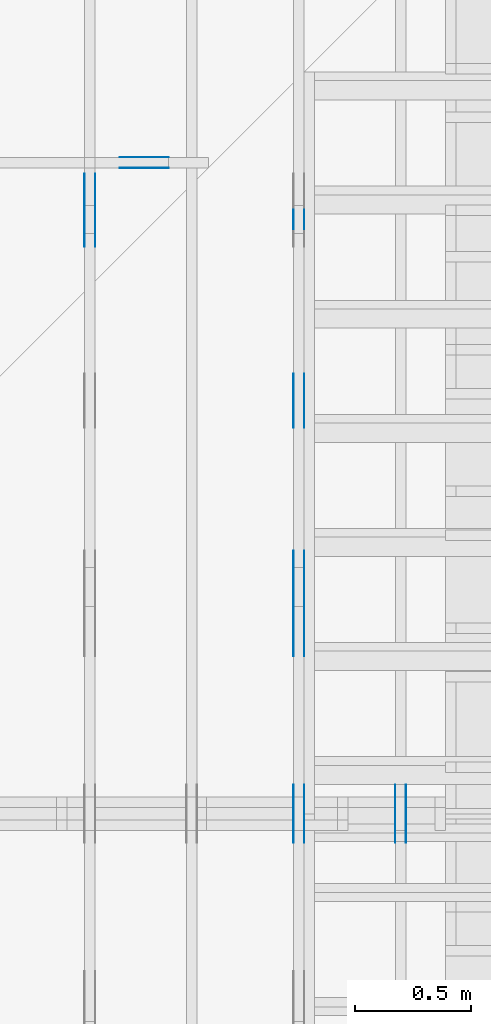
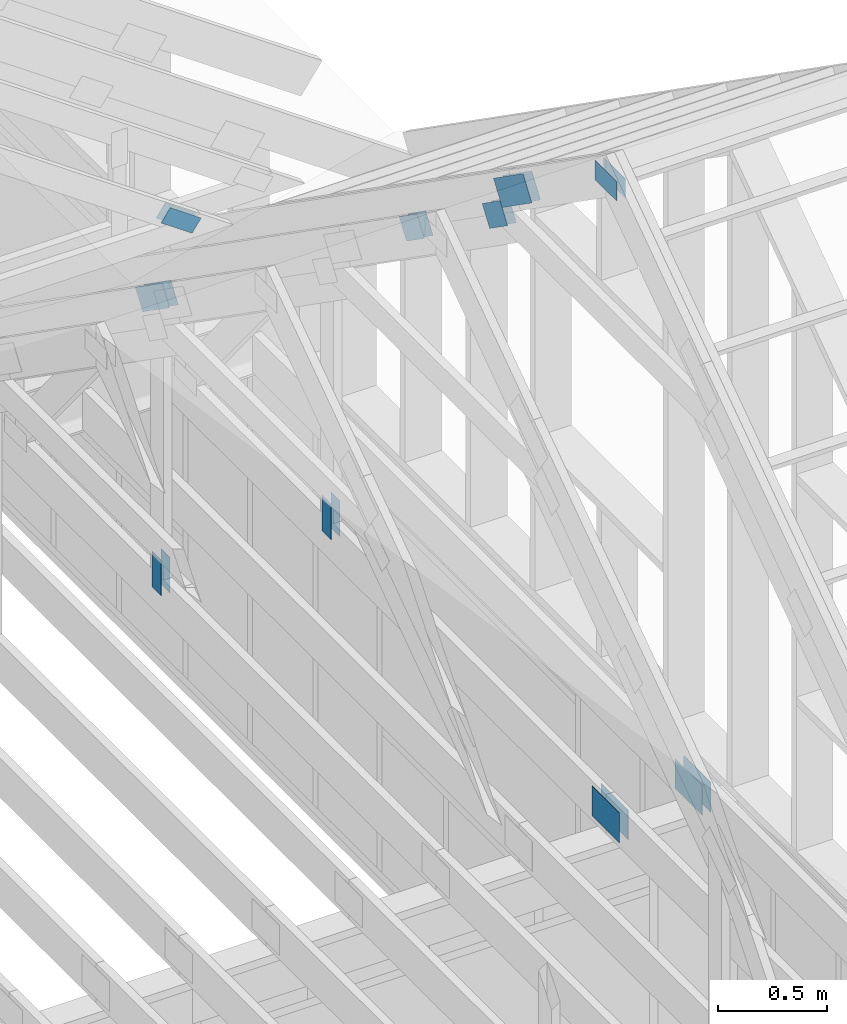
# One storey, part 58 of 70: 20 plates, 4 elements without a shape of their own.
"""IFC2X3 building model written with IfcOpenShell, lengths in millimetres."""

import ifcopenshell
import ifcopenshell.guid

model = None  # the IFC model being written
_history = None  # IfcOwnerHistory: only IFC2X3 demands one
_inside = {}  # id of a spatial element -> (the spatial element, [elements in it])
_under = {}  # id of a project, library or spatial element -> (it, [spatial elements below it])
_declared = {}  # id of a project -> (the project, [libraries it declares])
_typed = {}  # id of a type object -> (the type object, [elements of that type])
_made_of = {}  # id of a material, layer set ... -> (it, [elements and type objects made of it])


def new_model(schema):
    """Start an empty IFC model of exactly this schema.

    Asked for "IFC4X3", IfcOpenShell would pick the latest addendum, in which some entities
    have other attributes; the version numbers below select the first issue.
    IFC2X3 requires an IfcOwnerHistory on every rooted entity: one is made here for all.
    """
    global model, _history
    if schema == "IFC4X3":
        model = ifcopenshell.file(schema_version=(4, 3, 0, 0))
    else:
        model = ifcopenshell.file(schema=schema)
    _inside.clear()
    _under.clear()
    _declared.clear()
    _typed.clear()
    _made_of.clear()
    _history = None
    if model.schema == "IFC2X3":
        org = make("IfcOrganization", Name="unknown")
        user = make(
            "IfcPersonAndOrganization",
            ThePerson=make("IfcPerson", FamilyName="unknown"),
            TheOrganization=org,
        )
        app = make(
            "IfcApplication",
            ApplicationDeveloper=org,
            Version="unknown",
            ApplicationFullName="unknown",
            ApplicationIdentifier="unknown",
        )
        _history = make(
            "IfcOwnerHistory",
            OwningUser=user,
            OwningApplication=app,
            ChangeAction="ADDED",
            CreationDate=0,
        )
    return model


def make(cls, **values):
    """One entity of the class cls with the attributes given. An attribute that is None is left unset."""
    return model.create_entity(
        cls, **{name: value for name, value in values.items() if value is not None}
    )


def rooted(cls, **values):
    """An entity with a GlobalId (a new one), such as an element, a storey or a relation."""
    return make(cls, GlobalId=ifcopenshell.guid.new(), OwnerHistory=_history, **values)


def si_unit(unit_type, name, prefix=None):
    """IfcSIUnit, for example si_unit("LENGTHUNIT", "METRE", prefix="MILLI")."""
    return make("IfcSIUnit", UnitType=unit_type, Prefix=prefix, Name=name)


def assignment(units):
    """IfcUnitAssignment: the units of a project."""
    return None if units is None else make("IfcUnitAssignment", Units=units)


def point(xyz):
    """IfcCartesianPoint."""
    return None if xyz is None else make("IfcCartesianPoint", Coordinates=xyz)


def direction(xyz):
    """IfcDirection."""
    return None if xyz is None else make("IfcDirection", DirectionRatios=xyz)


def frame(location, z_axis=None, x_axis=None):
    """IfcAxis2Placement3D, a coordinate frame: its origin and axes. An axis left out is left unset."""
    return make(
        "IfcAxis2Placement3D",
        Location=point(location),
        Axis=direction(z_axis),
        RefDirection=direction(x_axis),
    )


def frame_2d(location, x_axis=None):
    """IfcAxis2Placement2D, a coordinate frame in the plane: its origin and x axis."""
    return make(
        "IfcAxis2Placement2D", Location=point(location), RefDirection=direction(x_axis)
    )


def origin():
    """The frame at (0, 0, 0) with its axes left unset."""
    return frame((0.0, 0.0, 0.0))


def origin_with_axes():
    """The frame at (0, 0, 0) with the z axis (0, 0, 1) and the x axis (1, 0, 0) written out."""
    return frame((0.0, 0.0, 0.0), z_axis=(0.0, 0.0, 1.0), x_axis=(1.0, 0.0, 0.0))


def origin_2d():
    """The frame at (0, 0) in the plane with its x axis left unset."""
    return frame_2d((0.0, 0.0))


def place(relative_to, where):
    """IfcLocalPlacement: puts the frame where relative to a parent placement (None: the world)."""
    return make(
        "IfcLocalPlacement", PlacementRelTo=relative_to, RelativePlacement=where
    )


def context(
    kind, dimensions, precision=None, world=None, true_north=None, identifier=None
):
    """IfcGeometricRepresentationContext, for example the 3D "Model" context."""
    return make(
        "IfcGeometricRepresentationContext",
        ContextIdentifier=identifier,
        ContextType=kind,
        CoordinateSpaceDimension=dimensions,
        Precision=precision,
        WorldCoordinateSystem=world,
        TrueNorth=true_north,
    )


def project(units=None, contexts=None):
    """IfcProject with its units and contexts."""
    return rooted(
        "IfcProject",
        Name="project",
        RepresentationContexts=contexts,
        UnitsInContext=assignment(units),
    )


def spatial(cls, under=None, at=None, **own):
    """A site, building, storey or space (cls), placed at a placement, below another one or the project."""
    s = rooted(cls, ObjectPlacement=at, **own)
    if under is not None:
        _under.setdefault(under.id(), (under, []))[1].append(s)
    return s


def faces_of(points, faces, orient=None, outer=None):
    """IfcFace entities. A face is a list of loops; a loop is a list of indices into points, from 0.

    orient and outer hold one flag for each loop. By default every Orientation is true, the
    first loop of a face is its IfcFaceOuterBound and the others are IfcFaceBound.
    """
    made = []
    for i, loops in enumerate(faces):
        bounds = []
        for j, loop in enumerate(loops):
            is_outer = j == 0 if outer is None else outer[i][j]
            bounds.append(
                make(
                    "IfcFaceOuterBound" if is_outer else "IfcFaceBound",
                    Bound=make("IfcPolyLoop", Polygon=[points[k] for k in loop]),
                    Orientation=True if orient is None else orient[i][j],
                )
            )
        made.append(make("IfcFace", Bounds=bounds))
    return made


def faceted_brep(points, faces, orient=None, outer=None, voids=None):
    """IfcFacetedBrep: a solid bounded by flat faces; with voids (closed shells), ...WithVoids."""
    shared = [point(p) for p in points]
    hull = make("IfcClosedShell", CfsFaces=faces_of(shared, faces, orient, outer))
    if voids is None:
        return make("IfcFacetedBrep", Outer=hull)
    return make(
        "IfcFacetedBrepWithVoids",
        Outer=hull,
        Voids=[
            make(cls, CfsFaces=faces_of(shared, fs, o, b)) for cls, fs, o, b in voids
        ],
    )


def shape(context_of_items, identifier, shape_type, items):
    """IfcShapeRepresentation: the items that make up one representation, for example the "Body"."""
    return make(
        "IfcShapeRepresentation",
        ContextOfItems=context_of_items,
        RepresentationIdentifier=identifier,
        RepresentationType=shape_type,
        Items=items,
    )


def made_of(thing, what):
    """Note that an element or type object is made of a material, layer set ...; save() writes the relation."""
    if what is not None:
        _made_of.setdefault(what.id(), (what, []))[1].append(thing)
    return thing


def element(
    cls,
    number,
    at=None,
    inside=None,
    cuts=None,
    type_object=None,
    material=None,
    context=None,
    identifier="Body",
    shape_type=None,
    held_by="IfcProductDefinitionShape",
    body=None,
    shapes=None,
    **own,
):
    """One element of the class cls, such as IfcWall. Its Tag is "e" and its number.

    at: its placement. inside: the storey or other place that contains it. cuts: it is an
    opening in that element (IfcRelVoidsElement). A single representation is given by context,
    identifier, shape_type and body (its items); several are given by shapes. held_by: the class
    of the entity that holds the representations. save() writes the other relations.
    """
    e = rooted(cls, Tag="e%d" % number, ObjectPlacement=at, **own)
    if body is not None:
        shapes = [shape(context, identifier, shape_type, body)]
    if shapes is not None:
        e.Representation = make(held_by, Representations=shapes)
    if inside is not None:
        _inside.setdefault(inside.id(), (inside, []))[1].append(e)
    if cuts is not None:
        rooted(
            "IfcRelVoidsElement", RelatingBuildingElement=cuts, RelatedOpeningElement=e
        )
    if type_object is not None:
        _typed.setdefault(type_object.id(), (type_object, []))[1].append(e)
    return made_of(e, material)


def aggregate(whole, parts):
    """IfcRelAggregates: a whole, such as a stair, and the parts it consists of."""
    return rooted("IfcRelAggregates", RelatingObject=whole, RelatedObjects=parts)


def save(model, path):
    """Write the relations noted so far, then the file.

    IfcRelAggregates (storeys below a building ...), IfcRelContainedInSpatialStructure (elements
    in a storey), IfcRelDefinesByType, IfcRelAssociatesMaterial and IfcRelDeclares: one each for
    every whole, place, type object, material and project.
    """
    for whole, parts in _under.values():
        aggregate(whole, parts)
    for where, things in _inside.values():
        rooted(
            "IfcRelContainedInSpatialStructure",
            RelatedElements=things,
            RelatingStructure=where,
        )
    for kind, things in _typed.values():
        rooted("IfcRelDefinesByType", RelatedObjects=things, RelatingType=kind)
    for what, things in _made_of.values():
        rooted("IfcRelAssociatesMaterial", RelatedObjects=things, RelatingMaterial=what)
    for by, libraries in _declared.values():
        rooted("IfcRelDeclares", RelatingContext=by, RelatedDefinitions=libraries)
    model.write(path)


model = new_model("IFC2X3")

# Units and contexts
model_context = context("Model", 3, precision=1e-05, world=origin())
plan_context = context("Plan", 2, precision=1e-05, world=origin_2d())
ifc_project = project(units=[si_unit("LENGTHUNIT", "METRE", prefix="MILLI"), si_unit("AREAUNIT", "SQUARE_METRE"), si_unit("VOLUMEUNIT", "CUBIC_METRE"), si_unit("SOLIDANGLEUNIT", "STERADIAN"), si_unit("PLANEANGLEUNIT", "RADIAN"), si_unit("MASSUNIT", "GRAM"), si_unit("TIMEUNIT", "SECOND"), si_unit("THERMODYNAMICTEMPERATUREUNIT", "DEGREE_CELSIUS"), si_unit("LUMINOUSINTENSITYUNIT", "LUMEN")], contexts=[model_context, plan_context])

# Site, building, storey
site_placement = place(None, origin_with_axes())
site = spatial("IfcSite", under=ifc_project, at=site_placement, CompositionType="ELEMENT")
building_placement = place(site_placement, origin_with_axes())
building = spatial("IfcBuilding", under=site, at=building_placement, Name="Layout 1", CompositionType="ELEMENT")
storey_placement = place(building_placement, origin_with_axes())
storey = spatial("IfcBuildingStorey", under=building, at=storey_placement, Name="Storey 1", CompositionType="ELEMENT", Elevation=0.0)

# Assembly, plates
assembly_1_placement = place(storey_placement, frame((11588.750000000146, 8000.0, 1.3776821480501744e-15), z_axis=(-1.0, 1.836909530733566e-16, 6.123031769111886e-17), x_axis=(-1.836909530733566e-16, -1.0, 0.0)))
assembly_1 = element("IfcElementAssembly", 1, at=assembly_1_placement, inside=storey, Name="MB1", AssemblyPlace="FACTORY", PredefinedType="TRUSS")
plate_1_placement = place(assembly_1_placement, frame((4125.0, 193.99999999999994, 0.0), z_axis=(0.0, 0.0, 1.0), x_axis=(-1.0, 1.2246063538223773e-16, 0.0)))
plate_1 = element("IfcPlate", 2, at=plate_1_placement, context=model_context, shape_type="Brep", body=[
    faceted_brep([(250.0, 168.0, 1.3), (0.0, 168.0, 1.3), (0.0, 0.0, 1.3), (250.0, 0.0, 1.3), (0.0, 168.0, 0.0), (250.0, 168.0, 3.061515884555943e-14), (250.0, 0.0, 3.061515884555943e-14), (0.0, 0.0, 0.0), (250.0, -4.592273826833915e-14, 2.8118638534165077e-30), (250.0, -4.5843138855340694e-14, 1.3), (1.4621692037765842e-32, 7.959941299845453e-17, 1.3), (0.0, 0.0, 0.0), (250.0, 168.0, 0.0), (250.0, 168.0, 1.3), (250.0, 0.0, 1.3), (250.0, 0.0, 0.0), (0.0, 168.0, 0.0), (-4.8738973459219465e-33, 168.0, 1.3), (250.0, 167.99999999999997, 1.3), (250.0, 167.99999999999997, -1.5777218104420236e-30), (0.0, 0.0, 0.0), (7.959941299845453e-17, -9.747794691843893e-33, 1.3), (2.065298615721439e-14, 168.0, 1.3), (2.0573386744215938e-14, 168.0, -1.2597150063305954e-30)], [[[0, 1, 2, 3]], [[4, 5, 6, 7]], [[8, 9, 10, 11]], [[12, 13, 14, 15]], [[16, 17, 18, 19]], [[20, 21, 22, 23]]]),
])
plate_2_placement = place(assembly_1_placement, frame((4125.0, 193.99999999999994, -46.3), z_axis=(0.0, 0.0, 1.0), x_axis=(-1.0, 1.2246063538223773e-16, 0.0)))
plate_2 = element("IfcPlate", 3, at=plate_2_placement, context=model_context, shape_type="Brep", body=[
    faceted_brep([(250.0, 168.0, 1.2999999999999972), (0.0, 168.0, 1.2999999999999972), (0.0, 0.0, 1.2999999999999972), (250.0, 0.0, 1.2999999999999972), (0.0, 168.0, 0.0), (250.0, 168.0, 3.061515884555943e-14), (250.0, 0.0, 3.061515884555943e-14), (0.0, 0.0, 0.0), (250.0, -4.592273826833915e-14, 2.8118638534165077e-30), (250.0, -4.5843138855340694e-14, 1.2999999999999972), (1.462169203776581e-32, 7.959941299845434e-17, 1.2999999999999972), (0.0, 0.0, 0.0), (250.0, 168.0, 0.0), (250.0, 168.0, 1.2999999999999972), (250.0, 0.0, 1.2999999999999972), (250.0, 0.0, 0.0), (0.0, 168.0, 0.0), (-4.873897345921936e-33, 168.0, 1.2999999999999972), (250.0, 167.99999999999997, 1.2999999999999972), (250.0, 167.99999999999997, -1.5777218104420236e-30), (0.0, 0.0, 0.0), (7.959941299845434e-17, -9.747794691843873e-33, 1.2999999999999972), (2.065298615721439e-14, 168.0, 1.2999999999999972), (2.0573386744215938e-14, 168.0, -1.2597150063305954e-30)], [[[0, 1, 2, 3]], [[4, 5, 6, 7]], [[8, 9, 10, 11]], [[12, 13, 14, 15]], [[16, 17, 18, 19]], [[20, 21, 22, 23]]]),
])
aggregate(assembly_1, [plate_1, plate_2])

assembly_2_placement = place(storey_placement, frame((10250.0, 8000.0, -9.081170196248781e-13), z_axis=(-1.0, 1.836909530733566e-16, 6.123031769111886e-17), x_axis=(-1.836909530733566e-16, -1.0, 0.0)))
assembly_2 = element("IfcElementAssembly", 4, at=assembly_2_placement, inside=storey, Name="T3", AssemblyPlace="FACTORY", PredefinedType="TRUSS")
plate_3_placement = place(assembly_2_placement, frame((1482.0000000018263, 120.0, 0.0), z_axis=(0.0, 0.0, 1.0), x_axis=(6.123031769111886e-17, 1.0, 0.0)))
plate_3 = element("IfcPlate", 5, at=plate_3_placement, context=model_context, shape_type="Brep", body=[
    faceted_brep([(200.00000000000003, 84.0, 1.3), (0.0, 84.0, 1.3), (0.0, 0.0, 1.3), (200.00000000000003, 0.0, 1.3), (0.0, 84.0, 0.0), (200.00000000000003, 84.0, 2.4492127076447548e-14), (200.00000000000003, 0.0, 2.4492127076447548e-14), (0.0, 0.0, 0.0), (200.00000000000003, -3.6738190614671324e-14, 2.2494910827332065e-30), (200.00000000000003, -3.665859120167287e-14, 1.3), (1.4621692037765842e-32, 7.959941299845453e-17, 1.3), (0.0, 0.0, 0.0), (200.00000000000003, 84.0, 0.0), (200.00000000000003, 84.0, 1.3), (200.00000000000003, 0.0, 1.3), (200.00000000000003, 0.0, 0.0), (0.0, 84.0, 0.0), (-4.8738973459219465e-33, 84.0, 1.3), (200.00000000000003, 83.99999999999999, 1.3), (200.00000000000003, 83.99999999999999, -7.888609052210118e-31), (0.0, 0.0, 0.0), (7.959941299845453e-17, -9.747794691843893e-33, 1.3), (1.0366292785106424e-14, 84.0, 1.3), (1.0286693372107969e-14, 84.0, -6.298575031652977e-31)], [[[0, 1, 2, 3]], [[4, 5, 6, 7]], [[8, 9, 10, 11]], [[12, 13, 14, 15]], [[16, 17, 18, 19]], [[20, 21, 22, 23]]]),
])
plate_4_placement = place(assembly_2_placement, frame((1482.0000000018263, 120.0, -46.3), z_axis=(0.0, 0.0, 1.0), x_axis=(6.123031769111886e-17, 1.0, 0.0)))
plate_4 = element("IfcPlate", 6, at=plate_4_placement, context=model_context, shape_type="Brep", body=[
    faceted_brep([(200.00000000000003, 84.0, 1.2999999999999972), (0.0, 84.0, 1.2999999999999972), (0.0, 0.0, 1.2999999999999972), (200.00000000000003, 0.0, 1.2999999999999972), (0.0, 84.0, 0.0), (200.00000000000003, 84.0, 2.4492127076447548e-14), (200.00000000000003, 0.0, 2.4492127076447548e-14), (0.0, 0.0, 0.0), (200.00000000000003, -3.6738190614671324e-14, 2.2494910827332065e-30), (200.00000000000003, -3.665859120167287e-14, 1.2999999999999972), (1.462169203776581e-32, 7.959941299845434e-17, 1.2999999999999972), (0.0, 0.0, 0.0), (200.00000000000003, 84.0, 0.0), (200.00000000000003, 84.0, 1.2999999999999972), (200.00000000000003, 0.0, 1.2999999999999972), (200.00000000000003, 0.0, 0.0), (0.0, 84.0, 0.0), (-4.873897345921936e-33, 84.0, 1.2999999999999972), (200.00000000000003, 83.99999999999999, 1.2999999999999972), (200.00000000000003, 83.99999999999999, -7.888609052210118e-31), (0.0, 0.0, 0.0), (7.959941299845434e-17, -9.747794691843873e-33, 1.2999999999999972), (1.0366292785106424e-14, 84.0, 1.2999999999999972), (1.0286693372107969e-14, 84.0, -6.298575031652977e-31)], [[[0, 1, 2, 3]], [[4, 5, 6, 7]], [[8, 9, 10, 11]], [[12, 13, 14, 15]], [[16, 17, 18, 19]], [[20, 21, 22, 23]]]),
])
plate_5_placement = place(assembly_2_placement, frame((1312.2224814137073, 1607.5305531611004, 0.0), z_axis=(0.0, 0.0, 1.0), x_axis=(0.8191520442886487, 0.5735764363515361, 0.0)))
plate_5 = element("IfcPlate", 7, at=plate_5_placement, context=model_context, shape_type="Brep", body=[
    faceted_brep([(300.00000000000045, 120.0, 1.3), (0.0, 120.0, 1.3), (4.547473508864641e-13, 0.0, 1.3), (300.00000000000045, 0.0, 1.3), (0.0, 120.0, 0.0), (300.00000000000045, 120.0, 3.6738190614671375e-14), (300.00000000000045, 1.1368683772161603e-13, 3.6738190614671375e-14), (4.547473508864641e-13, 1.1368683772161603e-13, 5.56886495279458e-29), (300.00000000000045, -5.510728592200723e-14, 1.0335317815093051e-29), (300.00000000000045, -5.5027686509008776e-14, 1.3), (4.547473508864641e-13, 7.959941299819867e-17, 1.3), (4.547473508864641e-13, -2.558622685737995e-28, 1.566652798994412e-44), (300.00000000000045, 120.00000000000011, 0.0), (300.00000000000045, 120.00000000000011, 1.3), (300.00000000000045, 1.1368683772161603e-13, 1.3), (300.00000000000045, 1.1368683772161603e-13, 0.0), (0.0, 120.0, 0.0), (0.0, 120.0, 1.3), (300.00000000000045, 120.00000000000011, 1.3), (300.00000000000045, 120.00000000000011, 0.0), (4.547473508864641e-13, 0.0, 0.0), (4.548269502994626e-13, 2.730461286921124e-31, 1.3), (4.319658508927097e-14, 120.0, 1.3), (4.3116985676272535e-14, 120.0, -2.6400667308415888e-30)], [[[0, 1, 2, 3]], [[4, 5, 6, 7]], [[8, 9, 10, 11]], [[12, 13, 14, 15]], [[16, 17, 18, 19]], [[20, 21, 22, 23]]]),
])
plate_6_placement = place(assembly_2_placement, frame((1312.2224814137073, 1607.5305531611004, -46.300000000000004), z_axis=(0.0, 0.0, 1.0), x_axis=(0.8191520442886487, 0.5735764363515361, 0.0)))
plate_6 = element("IfcPlate", 8, at=plate_6_placement, context=model_context, shape_type="Brep", body=[
    faceted_brep([(300.00000000000045, 120.0, 1.2999999999999972), (0.0, 120.0, 1.2999999999999972), (4.547473508864641e-13, 0.0, 1.2999999999999972), (300.00000000000045, 0.0, 1.2999999999999972), (0.0, 120.0, 0.0), (300.00000000000045, 120.0, 3.6738190614671375e-14), (300.00000000000045, 1.1368683772161603e-13, 3.6738190614671375e-14), (4.547473508864641e-13, 1.1368683772161603e-13, 5.56886495279458e-29), (300.00000000000045, -5.510728592200723e-14, 1.0335317815093051e-29), (300.00000000000045, -5.5027686509008776e-14, 1.2999999999999972), (4.547473508864641e-13, 7.959941299819848e-17, 1.2999999999999972), (4.547473508864641e-13, -2.558622685737995e-28, 1.566652798994412e-44), (300.00000000000045, 120.00000000000011, 0.0), (300.00000000000045, 120.00000000000011, 1.2999999999999972), (300.00000000000045, 1.1368683772161603e-13, 1.2999999999999972), (300.00000000000045, 1.1368683772161603e-13, 0.0), (0.0, 120.0, 0.0), (0.0, 120.0, 1.2999999999999972), (300.00000000000045, 120.00000000000011, 1.2999999999999972), (300.00000000000045, 120.00000000000011, 0.0), (4.547473508864641e-13, 0.0, 0.0), (4.548269502994626e-13, 2.730461286921124e-31, 1.2999999999999972), (4.319658508927097e-14, 120.0, 1.2999999999999972), (4.3116985676272535e-14, 120.0, -2.6400667308415888e-30)], [[[0, 1, 2, 3]], [[4, 5, 6, 7]], [[8, 9, 10, 11]], [[12, 13, 14, 15]], [[16, 17, 18, 19]], [[20, 21, 22, 23]]]),
])
aggregate(assembly_2, [plate_3, plate_4, plate_5, plate_6])

assembly_3_placement = place(storey_placement, frame((11150.0, 8000.0, -9.081170196248781e-13), z_axis=(-1.0, 1.836909530733566e-16, 6.123031769111886e-17), x_axis=(-1.836909530733566e-16, -1.0, 0.0)))
assembly_3 = element("IfcElementAssembly", 9, at=assembly_3_placement, inside=storey, Name="T3", AssemblyPlace="FACTORY", PredefinedType="TRUSS")
plate_7_placement = place(assembly_3_placement, frame((2172.1001375452647, 2209.623369923266, 0.0), z_axis=(0.0, 0.0, 1.0), x_axis=(0.8191520442889915, 0.5735764363510465, 0.0)))
plate_7 = element("IfcPlate", 10, at=plate_7_placement, context=model_context, shape_type="Brep", body=[
    faceted_brep([(200.00000000000045, 120.0, 1.3), (0.0, 120.0, 1.3), (0.0, 0.0, 1.3), (200.00000000000045, 0.0, 1.3), (0.0, 120.0, 0.0), (200.00000000000045, 120.0, 2.4492127076447602e-14), (200.00000000000045, 2.2737367544323206e-13, 2.4492127076447602e-14), (0.0, 2.2737367544323206e-13, 0.0), (200.00000000000045, 1.4089749332535406e-13, 5.2949641037927226e-30), (200.00000000000045, 1.4097709273835252e-13, 1.3), (-5.607678880825911e-32, 7.959941299845453e-17, 1.3), (0.0, 0.0, 0.0), (200.00000000000045, 120.00000000000023, 0.0), (200.00000000000045, 120.00000000000023, 1.3), (200.00000000000045, 2.2737367544323206e-13, 1.3), (200.00000000000045, 2.2737367544323206e-13, 0.0), (0.0, 120.0, 0.0), (0.0, 120.0, 1.3), (200.00000000000043, 120.00000000000021, 1.3), (200.00000000000043, 120.00000000000021, -1.5777218104420236e-30), (0.0, 0.0, 0.0), (7.959941299845453e-17, -9.747794691843893e-33, 1.3), (1.477487565886698e-14, 120.0, 1.3), (1.4695276245868527e-14, 120.0, -8.997964330932825e-31)], [[[0, 1, 2, 3]], [[4, 5, 6, 7]], [[8, 9, 10, 11]], [[12, 13, 14, 15]], [[16, 17, 18, 19]], [[20, 21, 22, 23]]]),
])
plate_8_placement = place(assembly_3_placement, frame((2172.1001375452647, 2209.623369923266, -46.29999999999999), z_axis=(0.0, 0.0, 1.0), x_axis=(0.8191520442889915, 0.5735764363510465, 0.0)))
plate_8 = element("IfcPlate", 11, at=plate_8_placement, context=model_context, shape_type="Brep", body=[
    faceted_brep([(200.00000000000045, 120.0, 1.2999999999999972), (0.0, 120.0, 1.2999999999999972), (0.0, 0.0, 1.2999999999999972), (200.00000000000045, 0.0, 1.2999999999999972), (0.0, 120.0, 0.0), (200.00000000000045, 120.0, 2.4492127076447602e-14), (200.00000000000045, 2.2737367544323206e-13, 2.4492127076447602e-14), (0.0, 2.2737367544323206e-13, 0.0), (200.00000000000045, 1.4089749332535406e-13, 5.2949641037927226e-30), (200.00000000000045, 1.4097709273835252e-13, 1.2999999999999972), (-5.607678880825899e-32, 7.959941299845434e-17, 1.2999999999999972), (0.0, 0.0, 0.0), (200.00000000000045, 120.00000000000023, 0.0), (200.00000000000045, 120.00000000000023, 1.2999999999999972), (200.00000000000045, 2.2737367544323206e-13, 1.2999999999999972), (200.00000000000045, 2.2737367544323206e-13, 0.0), (0.0, 120.0, 0.0), (0.0, 120.0, 1.2999999999999972), (200.00000000000043, 120.00000000000021, 1.2999999999999972), (200.00000000000043, 120.00000000000021, -1.5777218104420236e-30), (0.0, 0.0, 0.0), (7.959941299845434e-17, -9.747794691843873e-33, 1.2999999999999972), (1.477487565886698e-14, 120.0, 1.2999999999999972), (1.4695276245868527e-14, 120.0, -8.997964330932825e-31)], [[[0, 1, 2, 3]], [[4, 5, 6, 7]], [[8, 9, 10, 11]], [[12, 13, 14, 15]], [[16, 17, 18, 19]], [[20, 21, 22, 23]]]),
])
plate_9_placement = place(assembly_3_placement, frame((2935.3889881921987, 2744.0839769784025, 0.0), z_axis=(0.0, 0.0, 1.0), x_axis=(0.8191520442889915, 0.5735764363510465, 0.0)))
plate_9 = element("IfcPlate", 12, at=plate_9_placement, context=model_context, shape_type="Brep", body=[
    faceted_brep([(200.00000000000045, 120.00000000000045, 1.3), (4.547473508864641e-13, 120.00000000000045, 1.3), (0.0, 0.0, 1.3), (200.00000000000045, 0.0, 1.3), (4.547473508864641e-13, 120.00000000000045, 5.56886495279458e-29), (200.00000000000045, 120.00000000000045, 2.4492127076447602e-14), (200.00000000000045, 4.547473508864641e-13, 2.4492127076447602e-14), (0.0, 4.547473508864641e-13, 0.0), (200.00000000000045, 3.185331772653795e-13, 8.340437124852233e-30), (200.00000000000045, 3.186127766783779e-13, 1.3), (-1.2677526965428406e-31, 7.959941299845453e-17, 1.3), (0.0, 0.0, 0.0), (200.00000000000045, 119.99999999999977, 0.0), (200.00000000000045, 119.99999999999977, 1.3), (200.00000000000045, 4.547473508864641e-13, 1.3), (200.00000000000045, 4.547473508864641e-13, 0.0), (4.547473508864641e-13, 120.00000000000045, 0.0), (4.547473508864641e-13, 120.00000000000045, 1.3), (200.00000000000045, 119.99999999999982, 1.3), (200.00000000000045, 119.99999999999982, 3.1554436208840472e-30), (0.0, 0.0, 0.0), (7.959941299845453e-17, -2.9254171807594367e-31, 1.3), (4.4110051711492874e-13, 120.00000000000045, 1.3), (4.410209177019303e-13, 120.00000000000045, 8.40473864654923e-31)], [[[0, 1, 2, 3]], [[4, 5, 6, 7]], [[8, 9, 10, 11]], [[12, 13, 14, 15]], [[16, 17, 18, 19]], [[20, 21, 22, 23]]]),
])
plate_10_placement = place(assembly_3_placement, frame((2935.3889881921987, 2744.0839769784025, -46.29999999999999), z_axis=(0.0, 0.0, 1.0), x_axis=(0.8191520442889915, 0.5735764363510465, 0.0)))
plate_10 = element("IfcPlate", 13, at=plate_10_placement, context=model_context, shape_type="Brep", body=[
    faceted_brep([(200.00000000000045, 120.00000000000045, 1.2999999999999972), (4.547473508864641e-13, 120.00000000000045, 1.2999999999999972), (0.0, 0.0, 1.2999999999999972), (200.00000000000045, 0.0, 1.2999999999999972), (4.547473508864641e-13, 120.00000000000045, 5.56886495279458e-29), (200.00000000000045, 120.00000000000045, 2.4492127076447602e-14), (200.00000000000045, 4.547473508864641e-13, 2.4492127076447602e-14), (0.0, 4.547473508864641e-13, 0.0), (200.00000000000045, 3.185331772653795e-13, 8.340437124852233e-30), (200.00000000000045, 3.186127766783779e-13, 1.2999999999999972), (-1.2677526965428377e-31, 7.959941299845434e-17, 1.2999999999999972), (0.0, 0.0, 0.0), (200.00000000000045, 119.99999999999977, 0.0), (200.00000000000045, 119.99999999999977, 1.2999999999999972), (200.00000000000045, 4.547473508864641e-13, 1.2999999999999972), (200.00000000000045, 4.547473508864641e-13, 0.0), (4.547473508864641e-13, 120.00000000000045, 0.0), (4.547473508864641e-13, 120.00000000000045, 1.2999999999999972), (200.00000000000045, 119.99999999999982, 1.2999999999999972), (200.00000000000045, 119.99999999999982, 3.1554436208840472e-30), (0.0, 0.0, 0.0), (7.959941299845434e-17, -2.92541718075943e-31, 1.2999999999999972), (4.4110051711492874e-13, 120.00000000000045, 1.2999999999999972), (4.410209177019303e-13, 120.00000000000045, 8.40473864654923e-31)], [[[0, 1, 2, 3]], [[4, 5, 6, 7]], [[8, 9, 10, 11]], [[12, 13, 14, 15]], [[16, 17, 18, 19]], [[20, 21, 22, 23]]]),
])
plate_11_placement = place(assembly_3_placement, frame((4125.0, 194.0, 0.0), z_axis=(0.0, 0.0, 1.0), x_axis=(-1.0, 1.2246063538223773e-16, 0.0)))
plate_11 = element("IfcPlate", 14, at=plate_11_placement, context=model_context, shape_type="Brep", body=[
    faceted_brep([(250.0, 168.0, 1.3), (0.0, 168.0, 1.3), (0.0, 0.0, 1.3), (250.0, 0.0, 1.3), (0.0, 168.0, 0.0), (250.0, 168.0, 3.061515884555943e-14), (250.0, 0.0, 3.061515884555943e-14), (0.0, 0.0, 0.0), (250.0, -4.592273826833915e-14, 2.8118638534165077e-30), (250.0, -4.5843138855340694e-14, 1.3), (1.4621692037765842e-32, 7.959941299845453e-17, 1.3), (0.0, 0.0, 0.0), (250.0, 168.0, 0.0), (250.0, 168.0, 1.3), (250.0, 0.0, 1.3), (250.0, 0.0, 0.0), (0.0, 168.0, 0.0), (-4.8738973459219465e-33, 168.0, 1.3), (250.0, 167.99999999999997, 1.3), (250.0, 167.99999999999997, -1.5777218104420236e-30), (0.0, 0.0, 0.0), (7.959941299845453e-17, -9.747794691843893e-33, 1.3), (2.065298615721439e-14, 168.0, 1.3), (2.0573386744215938e-14, 168.0, -1.2597150063305954e-30)], [[[0, 1, 2, 3]], [[4, 5, 6, 7]], [[8, 9, 10, 11]], [[12, 13, 14, 15]], [[16, 17, 18, 19]], [[20, 21, 22, 23]]]),
])
plate_12_placement = place(assembly_3_placement, frame((4125.0, 194.0, -46.3), z_axis=(0.0, 0.0, 1.0), x_axis=(-1.0, 1.2246063538223773e-16, 0.0)))
plate_12 = element("IfcPlate", 15, at=plate_12_placement, context=model_context, shape_type="Brep", body=[
    faceted_brep([(250.0, 168.0, 1.2999999999999972), (0.0, 168.0, 1.2999999999999972), (0.0, 0.0, 1.2999999999999972), (250.0, 0.0, 1.2999999999999972), (0.0, 168.0, 0.0), (250.0, 168.0, 3.061515884555943e-14), (250.0, 0.0, 3.061515884555943e-14), (0.0, 0.0, 0.0), (250.0, -4.592273826833915e-14, 2.8118638534165077e-30), (250.0, -4.5843138855340694e-14, 1.2999999999999972), (1.462169203776581e-32, 7.959941299845434e-17, 1.2999999999999972), (0.0, 0.0, 0.0), (250.0, 168.0, 0.0), (250.0, 168.0, 1.2999999999999972), (250.0, 0.0, 1.2999999999999972), (250.0, 0.0, 0.0), (0.0, 168.0, 0.0), (-4.873897345921936e-33, 168.0, 1.2999999999999972), (250.0, 167.99999999999997, 1.2999999999999972), (250.0, 167.99999999999997, -1.5777218104420236e-30), (0.0, 0.0, 0.0), (7.959941299845434e-17, -9.747794691843873e-33, 1.2999999999999972), (2.065298615721439e-14, 168.0, 1.2999999999999972), (2.0573386744215938e-14, 168.0, -1.2597150063305954e-30)], [[[0, 1, 2, 3]], [[4, 5, 6, 7]], [[8, 9, 10, 11]], [[12, 13, 14, 15]], [[16, 17, 18, 19]], [[20, 21, 22, 23]]]),
])
plate_13_placement = place(assembly_3_placement, frame((3899.9999999999995, 3603.8046304341406, 0.0), z_axis=(0.0, 0.0, 1.0), x_axis=(1.0, 0.0, 0.0)))
plate_13 = element("IfcPlate", 16, at=plate_13_placement, context=model_context, shape_type="Brep", body=[
    faceted_brep([(200.00000000000045, 108.0, 1.3), (0.0, 108.0, 1.3), (0.0, 0.0, 1.3), (200.00000000000045, 0.0, 1.3), (0.0, 108.0, 0.0), (200.00000000000045, 108.0, 2.4492127076447602e-14), (200.00000000000045, 0.0, 2.4492127076447602e-14), (0.0, 0.0, 0.0), (200.00000000000045, -3.67381906146714e-14, 2.2494910827332114e-30), (200.00000000000045, -3.6658591201672947e-14, 1.3), (1.4621692037765842e-32, 7.959941299845453e-17, 1.3), (0.0, 0.0, 0.0), (200.00000000000045, 108.0, 0.0), (200.00000000000045, 108.0, 1.3), (200.00000000000045, 0.0, 1.3), (200.00000000000045, 0.0, 0.0), (0.0, 108.0, 0.0), (-4.8738973459219465e-33, 108.0, 1.3), (200.00000000000045, 107.99999999999999, 1.3), (200.00000000000045, 107.99999999999999, -7.888609052210118e-31), (0.0, 0.0, 0.0), (7.959941299845453e-17, -9.747794691843893e-33, 1.3), (1.330534803428013e-14, 108.0, 1.3), (1.3225748621281674e-14, 108.0, -8.098167897839542e-31)], [[[0, 1, 2, 3]], [[4, 5, 6, 7]], [[8, 9, 10, 11]], [[12, 13, 14, 15]], [[16, 17, 18, 19]], [[20, 21, 22, 23]]]),
])
plate_14_placement = place(assembly_3_placement, frame((3899.9999999999995, 3603.8046304341406, -46.3), z_axis=(0.0, 0.0, 1.0), x_axis=(1.0, 0.0, 0.0)))
plate_14 = element("IfcPlate", 17, at=plate_14_placement, context=model_context, shape_type="Brep", body=[
    faceted_brep([(200.00000000000045, 108.0, 1.2999999999999972), (0.0, 108.0, 1.2999999999999972), (0.0, 0.0, 1.2999999999999972), (200.00000000000045, 0.0, 1.2999999999999972), (0.0, 108.0, 0.0), (200.00000000000045, 108.0, 2.4492127076447602e-14), (200.00000000000045, 0.0, 2.4492127076447602e-14), (0.0, 0.0, 0.0), (200.00000000000045, -3.67381906146714e-14, 2.2494910827332114e-30), (200.00000000000045, -3.6658591201672947e-14, 1.2999999999999972), (1.462169203776581e-32, 7.959941299845434e-17, 1.2999999999999972), (0.0, 0.0, 0.0), (200.00000000000045, 108.0, 0.0), (200.00000000000045, 108.0, 1.2999999999999972), (200.00000000000045, 0.0, 1.2999999999999972), (200.00000000000045, 0.0, 0.0), (0.0, 108.0, 0.0), (-4.873897345921936e-33, 108.0, 1.2999999999999972), (200.00000000000045, 107.99999999999999, 1.2999999999999972), (200.00000000000045, 107.99999999999999, -7.888609052210118e-31), (0.0, 0.0, 0.0), (7.959941299845434e-17, -9.747794691843873e-33, 1.2999999999999972), (1.330534803428013e-14, 108.0, 1.2999999999999972), (1.3225748621281674e-14, 108.0, -8.098167897839542e-31)], [[[0, 1, 2, 3]], [[4, 5, 6, 7]], [[8, 9, 10, 11]], [[12, 13, 14, 15]], [[16, 17, 18, 19]], [[20, 21, 22, 23]]]),
])
plate_15_placement = place(assembly_3_placement, frame((3241.212504107585, 3235.9501271276167, 0.0), z_axis=(0.0, 0.0, 1.0), x_axis=(-0.8191520442889914, -0.5735764363510467, 0.0)))
plate_15 = element("IfcPlate", 18, at=plate_15_placement, context=model_context, shape_type="Brep", body=[
    faceted_brep([(330.0000000000009, 140.00000000000045, 1.5), (134.0000000000009, 140.00000000000045, 1.5), (134.0, 4.547473508864641e-13, 1.5), (330.0000000000009, 4.547473508864641e-13, 1.5), (133.9000001978775, 140.00000000000045, 1.5), (9.094947017729282e-13, 140.00000000000045, 1.5), (0.0, 4.547473508864641e-13, 1.5), (133.90000101970236, 4.547473508864641e-13, 1.5), (330.0000000000009, 140.00000000000045, 0.0), (134.0000000000009, 140.00000000000045, 0.0), (134.0, 4.547473508864641e-13, 0.0), (330.0000000000009, 4.547473508864641e-13, 0.0), (133.9000001978775, 140.00000000000045, 0.0), (9.094947017729282e-13, 140.00000000000045, 0.0), (0.0, 4.547473508864641e-13, 0.0), (133.90000101970236, 4.547473508864641e-13, 0.0), (330.0000000000009, 9.803270933743405e-13, -4.610357698653557e-29), (330.0000000000009, 9.804189388508772e-13, 1.5), (134.0, 6.682564251308046e-13, 1.5), (134.0, 6.681645796542679e-13, -4.091192948218372e-29), (133.90000101970236, 6.680053146896804e-13, 8.643095081543955e-31), (133.90000101970236, 6.680971601662171e-13, 1.5), (-1.4627915729340467e-31, 4.548391963630008e-13, 1.5), (0.0, 4.547473508864641e-13, 0.0), (133.90000101970236, 140.00000000000068, 5.032059779604519e-23), (133.90000101970236, 140.00000000000068, 1.5), (133.90000101970236, 6.821210263296962e-13, 1.5), (133.90000101970236, 6.821210263296962e-13, 0.0), (9.094947017729282e-13, 140.00000000000045, 0.0), (9.094947017729282e-13, 140.00000000000045, 1.5), (133.9000001978775, 140.00000000000068, 1.5), (133.9000001978775, 140.00000000000068, 1.5777218104420236e-30), (134.0000000000009, 140.00000000000068, 1.4199496293978212e-29), (134.0000000000009, 140.00000000000068, 1.5), (330.0000000000009, 140.00000000000102, 1.5), (330.0000000000009, 140.00000000000102, 2.208810534618833e-29), (5.56886495279458e-29, 4.547473508864641e-13, -3.409833702385498e-45), (9.184547653673398e-17, 4.547473508864641e-13, 1.5), (8.876511857361728e-13, 140.00000000000045, 1.5), (8.875593402596361e-13, 140.00000000000045, 1.3431091541284187e-30), (330.0000000000009, 140.00000000000068, 0.0), (330.0000000000009, 140.00000000000068, 1.5), (330.0000000000009, 2.2737367544323206e-13, 1.5), (330.0000000000009, 2.2737367544323206e-13, 0.0), (134.0, 0.0, 0.0), (134.0, 0.0, 1.5), (134.00000000000088, 140.00000000000045, 1.5), (134.00000000000088, 140.00000000000045, 1.5777218104420236e-30)], [[[0, 1, 2, 3]], [[4, 5, 6, 7]], [[8, 9, 10, 11]], [[12, 13, 14, 15]], [[16, 17, 18, 19]], [[20, 21, 22, 23]], [[24, 25, 26, 27]], [[28, 29, 30, 31]], [[32, 33, 34, 35]], [[36, 37, 38, 39]], [[40, 41, 42, 43]], [[44, 45, 46, 47]]]),
])
plate_16_placement = place(assembly_3_placement, frame((3241.212504107585, 3235.9501271276167, -46.5), z_axis=(0.0, 0.0, 1.0), x_axis=(-0.8191520442889914, -0.5735764363510467, 0.0)))
plate_16 = element("IfcPlate", 19, at=plate_16_placement, context=model_context, shape_type="Brep", body=[
    faceted_brep([(330.0000000000009, 140.00000000000045, 0.0), (134.0000000000009, 140.00000000000045, 0.0), (134.0, 4.547473508864641e-13, 0.0), (330.0000000000009, 4.547473508864641e-13, 0.0), (133.9000001978775, 140.00000000000045, 0.0), (9.094947017729282e-13, 140.00000000000045, 0.0), (0.0, 4.547473508864641e-13, 0.0), (133.90000101970236, 4.547473508864641e-13, 0.0), (330.0000000000009, 140.00000000000045, 1.5), (134.0000000000009, 140.00000000000045, 1.5), (134.0, 4.547473508864641e-13, 1.5), (330.0000000000009, 4.547473508864641e-13, 1.5), (133.9000001978775, 140.00000000000045, 1.5), (9.094947017729282e-13, 140.00000000000045, 1.5), (0.0, 4.547473508864641e-13, 1.5), (133.90000101970236, 4.547473508864641e-13, 1.5), (0.0, 4.547473508864641e-13, 0.0), (1.575266127070707e-31, 4.5465550540992744e-13, 1.5), (133.90000101970236, 6.843109484156988e-13, 1.5), (133.90000101970236, 6.844027938922355e-13, 1.397133527515671e-31), (134.0, 6.845743047954878e-13, 4.191670216580455e-29), (134.0, 6.844824593189511e-13, 1.5), (330.0000000000009, 1.0206472575739425e-12, 1.5), (330.0000000000009, 1.0207391030504792e-12, 4.85780171775421e-29), (133.90000101970236, 6.821210263296962e-13, 0.0), (133.90000101970236, 6.821210263296962e-13, 1.5), (133.90000019787752, 140.00000000000068, 1.5), (133.90000019787752, 140.00000000000068, 0.0), (330.0000000000009, 140.00000000000097, -1.8932661725304283e-29), (330.0000000000009, 140.00000000000097, 1.5), (134.00000000000094, 140.00000000000068, 1.5), (134.00000000000094, 140.00000000000068, -1.262177448353619e-29), (133.90000019787752, 140.00000000000068, 0.0), (133.90000019787752, 140.00000000000068, 1.5), (9.094947017729282e-13, 140.00000000000045, 1.5), (9.094947017729282e-13, 140.00000000000045, 0.0), (-2.8272774843121063e-27, 140.00000000000045, -5.568864952794597e-29), (-9.184547653950557e-17, 140.00000000000045, 1.5), (-9.184547653950557e-17, 4.547473508864641e-13, 1.5), (-2.8272774843121063e-27, 4.547473508864641e-13, -1.731150985653776e-43), (330.0000000000009, 2.2737367544323206e-13, 0.0), (330.0000000000009, 2.2737367544323206e-13, 1.5), (330.0000000000009, 140.00000000000068, 1.5), (330.0000000000009, 140.00000000000068, 0.0), (134.0, 140.00000000000045, -5.522026336547083e-29), (134.0, 140.00000000000045, 1.5), (134.0, 0.0, 1.5), (134.0, 0.0, 0.0)], [[[0, 1, 2, 3]], [[4, 5, 6, 7]], [[8, 9, 10, 11]], [[12, 13, 14, 15]], [[16, 17, 18, 19]], [[20, 21, 22, 23]], [[24, 25, 26, 27]], [[28, 29, 30, 31]], [[32, 33, 34, 35]], [[36, 37, 38, 39]], [[40, 41, 42, 43]], [[44, 45, 46, 47]]]),
])
plate_17_placement = place(assembly_3_placement, frame((1482.0000000018263, 120.0, 0.0), z_axis=(0.0, 0.0, 1.0), x_axis=(6.123031769111886e-17, 1.0, 0.0)))
plate_17 = element("IfcPlate", 20, at=plate_17_placement, context=model_context, shape_type="Brep", body=[
    faceted_brep([(200.00000000000003, 84.0, 1.3), (0.0, 84.0, 1.3), (0.0, 0.0, 1.3), (200.00000000000003, 0.0, 1.3), (0.0, 84.0, 0.0), (200.00000000000003, 84.0, 2.4492127076447548e-14), (200.00000000000003, 0.0, 2.4492127076447548e-14), (0.0, 0.0, 0.0), (200.00000000000003, -3.6738190614671324e-14, 2.2494910827332065e-30), (200.00000000000003, -3.665859120167287e-14, 1.3), (1.4621692037765842e-32, 7.959941299845453e-17, 1.3), (0.0, 0.0, 0.0), (200.00000000000003, 84.0, 0.0), (200.00000000000003, 84.0, 1.3), (200.00000000000003, 0.0, 1.3), (200.00000000000003, 0.0, 0.0), (0.0, 84.0, 0.0), (-4.8738973459219465e-33, 84.0, 1.3), (200.00000000000003, 83.99999999999999, 1.3), (200.00000000000003, 83.99999999999999, -7.888609052210118e-31), (0.0, 0.0, 0.0), (7.959941299845453e-17, -9.747794691843893e-33, 1.3), (1.0366292785106424e-14, 84.0, 1.3), (1.0286693372107969e-14, 84.0, -6.298575031652977e-31)], [[[0, 1, 2, 3]], [[4, 5, 6, 7]], [[8, 9, 10, 11]], [[12, 13, 14, 15]], [[16, 17, 18, 19]], [[20, 21, 22, 23]]]),
])
plate_18_placement = place(assembly_3_placement, frame((1482.0000000018263, 120.0, -46.3), z_axis=(0.0, 0.0, 1.0), x_axis=(6.123031769111886e-17, 1.0, 0.0)))
plate_18 = element("IfcPlate", 21, at=plate_18_placement, context=model_context, shape_type="Brep", body=[
    faceted_brep([(200.00000000000003, 84.0, 1.2999999999999972), (0.0, 84.0, 1.2999999999999972), (0.0, 0.0, 1.2999999999999972), (200.00000000000003, 0.0, 1.2999999999999972), (0.0, 84.0, 0.0), (200.00000000000003, 84.0, 2.4492127076447548e-14), (200.00000000000003, 0.0, 2.4492127076447548e-14), (0.0, 0.0, 0.0), (200.00000000000003, -3.6738190614671324e-14, 2.2494910827332065e-30), (200.00000000000003, -3.665859120167287e-14, 1.2999999999999972), (1.462169203776581e-32, 7.959941299845434e-17, 1.2999999999999972), (0.0, 0.0, 0.0), (200.00000000000003, 84.0, 0.0), (200.00000000000003, 84.0, 1.2999999999999972), (200.00000000000003, 0.0, 1.2999999999999972), (200.00000000000003, 0.0, 0.0), (0.0, 84.0, 0.0), (-4.873897345921936e-33, 84.0, 1.2999999999999972), (200.00000000000003, 83.99999999999999, 1.2999999999999972), (200.00000000000003, 83.99999999999999, -7.888609052210118e-31), (0.0, 0.0, 0.0), (7.959941299845434e-17, -9.747794691843873e-33, 1.2999999999999972), (1.0366292785106424e-14, 84.0, 1.2999999999999972), (1.0286693372107969e-14, 84.0, -6.298575031652977e-31)], [[[0, 1, 2, 3]], [[4, 5, 6, 7]], [[8, 9, 10, 11]], [[12, 13, 14, 15]], [[16, 17, 18, 19]], [[20, 21, 22, 23]]]),
])
aggregate(assembly_3, [plate_7, plate_8, plate_9, plate_10, plate_11, plate_12, plate_13, plate_14, plate_15, plate_16, plate_17, plate_18])

assembly_4_placement = place(storey_placement, frame((8194.999999999996, 6782.5, 1836.748008160603), z_axis=(0.0, -1.0, 6.123031769111886e-17), x_axis=(1.0, 0.0, 0.0)))
assembly_4 = element("IfcElementAssembly", 22, at=assembly_4_placement, inside=storey, Name="SB2", AssemblyPlace="FACTORY", PredefinedType="TRUSS")
plate_19_placement = place(assembly_4_placement, frame((2417.52084620912, 112.8014118347503, 0.0), z_axis=(0.0, 0.0, 1.0), x_axis=(-0.8191520442889914, 0.5735764363510467, 0.0)))
plate_19 = element("IfcPlate", 23, at=plate_19_placement, context=model_context, shape_type="Brep", body=[
    faceted_brep([(200.0, 84.0, 1.3), (2.2737367544323206e-13, 84.0, 1.3), (0.0, 0.0, 1.3), (200.0, 0.0, 1.3), (2.2737367544323206e-13, 84.0, 2.78443247639729e-29), (200.0, 84.0, 2.4492127076447545e-14), (200.0, 0.0, 2.4492127076447545e-14), (0.0, 0.0, 0.0), (200.0, -3.673819061467132e-14, 2.249491082733206e-30), (200.0, -3.6658591201672864e-14, 1.3), (1.4621692037765842e-32, 7.959941299845453e-17, 1.3), (0.0, 0.0, 0.0), (200.0, 84.0, 0.0), (200.0, 84.0, 1.3), (200.0, 0.0, 1.3), (200.0, 0.0, 0.0), (2.2737367544323206e-13, 84.0, 0.0), (2.2737367544323206e-13, 84.0, 1.3), (200.0, 83.99999999999999, 1.3), (200.0, 83.99999999999999, -7.888609052210118e-31), (0.0, 0.0, 0.0), (7.959941299845453e-17, -1.8649399680690625e-31, 1.3), (1.9688376092213273e-13, 84.0, 1.3), (1.9680416150913427e-13, 84.0, 1.8717810498478926e-30)], [[[0, 1, 2, 3]], [[4, 5, 6, 7]], [[8, 9, 10, 11]], [[12, 13, 14, 15]], [[16, 17, 18, 19]], [[20, 21, 22, 23]]]),
])
plate_20_placement = place(assembly_4_placement, frame((2417.52084620912, 112.8014118347503, -46.3), z_axis=(0.0, 0.0, 1.0), x_axis=(-0.8191520442889914, 0.5735764363510467, 0.0)))
plate_20 = element("IfcPlate", 24, at=plate_20_placement, context=model_context, shape_type="Brep", body=[
    faceted_brep([(200.0, 84.0, 1.2999999999999972), (2.2737367544323206e-13, 84.0, 1.2999999999999972), (0.0, 0.0, 1.2999999999999972), (200.0, 0.0, 1.2999999999999972), (2.2737367544323206e-13, 84.0, 2.78443247639729e-29), (200.0, 84.0, 2.4492127076447545e-14), (200.0, 0.0, 2.4492127076447545e-14), (0.0, 0.0, 0.0), (200.0, -3.673819061467132e-14, 2.249491082733206e-30), (200.0, -3.6658591201672864e-14, 1.2999999999999972), (1.462169203776581e-32, 7.959941299845434e-17, 1.2999999999999972), (0.0, 0.0, 0.0), (200.0, 84.0, 0.0), (200.0, 84.0, 1.2999999999999972), (200.0, 0.0, 1.2999999999999972), (200.0, 0.0, 0.0), (2.2737367544323206e-13, 84.0, 0.0), (2.2737367544323206e-13, 84.0, 1.2999999999999972), (200.0, 83.99999999999999, 1.2999999999999972), (200.0, 83.99999999999999, -7.888609052210118e-31), (0.0, 0.0, 0.0), (7.959941299845434e-17, -1.8649399680690586e-31, 1.2999999999999972), (1.9688376092213273e-13, 84.0, 1.2999999999999972), (1.9680416150913427e-13, 84.0, 1.8717810498478926e-30)], [[[0, 1, 2, 3]], [[4, 5, 6, 7]], [[8, 9, 10, 11]], [[12, 13, 14, 15]], [[16, 17, 18, 19]], [[20, 21, 22, 23]]]),
])
aggregate(assembly_4, [plate_19, plate_20])

save(model, "model.ifc")
